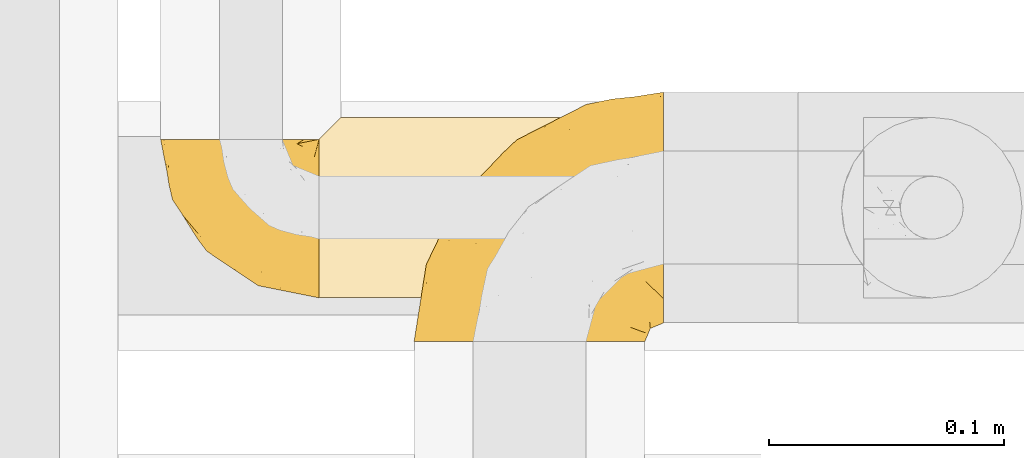
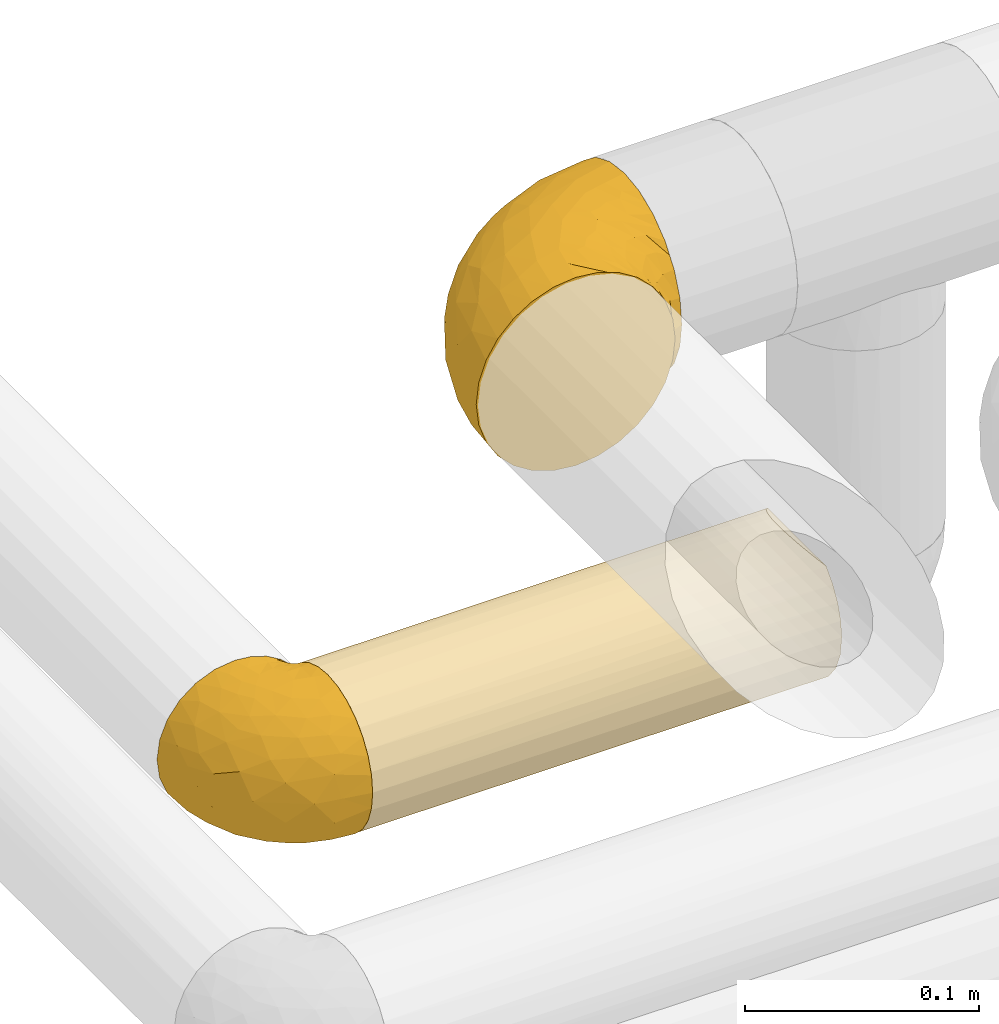
# One storey, part 361 of 827: 3 coverings.
"""IFC2X3 building model written with IfcOpenShell, lengths in millimetres."""

from ifc_helpers import new_model, entity, si_unit, converted_unit, derived_unit, direction, frame, origin, place, context, subcontext, project, spatial, faceted_brep, element, save


model = new_model("IFC2X3")

# Units and contexts
model_context = context("Model", 3, precision=0.01, world=origin(), true_north=direction((6.12303176911189e-17, 1.0)))
body_context = subcontext(model_context, "Body", "Model", "MODEL_VIEW")
ifc_project = project(units=[si_unit("LENGTHUNIT", "METRE", prefix="MILLI"), si_unit("AREAUNIT", "SQUARE_METRE"), si_unit("VOLUMEUNIT", "CUBIC_METRE"), converted_unit("PLANEANGLEUNIT", "DEGREE", entity("IfcRatioMeasure", 0.0174532925199433), si_unit("PLANEANGLEUNIT", "RADIAN"), dimensions=[0, 0, 0, 0, 0, 0, 0]), si_unit("MASSUNIT", "GRAM", prefix="KILO"), derived_unit("MASSDENSITYUNIT", [(si_unit("MASSUNIT", "GRAM", prefix="KILO"), 1), (si_unit("LENGTHUNIT", "METRE"), -3)]), derived_unit("MOMENTOFINERTIAUNIT", [(si_unit("LENGTHUNIT", "METRE"), 4)]), si_unit("TIMEUNIT", "SECOND"), si_unit("FREQUENCYUNIT", "HERTZ"), si_unit("THERMODYNAMICTEMPERATUREUNIT", "DEGREE_CELSIUS"), derived_unit("THERMALTRANSMITTANCEUNIT", [(si_unit("MASSUNIT", "GRAM", prefix="KILO"), 1), (si_unit("THERMODYNAMICTEMPERATUREUNIT", "KELVIN"), -1), (si_unit("TIMEUNIT", "SECOND"), -3)]), derived_unit("VOLUMETRICFLOWRATEUNIT", [(si_unit("LENGTHUNIT", "METRE"), 3), (si_unit("TIMEUNIT", "SECOND"), -1)]), derived_unit("MASSFLOWRATEUNIT", [(si_unit("MASSUNIT", "GRAM", prefix="KILO"), 1), (si_unit("TIMEUNIT", "SECOND"), -1)]), derived_unit("ROTATIONALFREQUENCYUNIT", [(si_unit("TIMEUNIT", "SECOND"), -1)]), si_unit("ELECTRICCURRENTUNIT", "AMPERE"), si_unit("ELECTRICVOLTAGEUNIT", "VOLT"), si_unit("POWERUNIT", "WATT"), si_unit("FORCEUNIT", "NEWTON", prefix="KILO"), si_unit("ILLUMINANCEUNIT", "LUX"), si_unit("LUMINOUSFLUXUNIT", "LUMEN"), si_unit("LUMINOUSINTENSITYUNIT", "CANDELA"), derived_unit("USERDEFINED", [(si_unit("MASSUNIT", "GRAM", prefix="KILO"), -1), (si_unit("LENGTHUNIT", "METRE"), -2), (si_unit("TIMEUNIT", "SECOND"), 3), (si_unit("LUMINOUSFLUXUNIT", "LUMEN"), 1)]), derived_unit("LINEARVELOCITYUNIT", [(si_unit("LENGTHUNIT", "METRE"), 1), (si_unit("TIMEUNIT", "SECOND"), -1)]), si_unit("PRESSUREUNIT", "PASCAL"), derived_unit("USERDEFINED", [(si_unit("LENGTHUNIT", "METRE"), -2), (si_unit("MASSUNIT", "GRAM", prefix="KILO"), 1), (si_unit("TIMEUNIT", "SECOND"), -2)]), derived_unit("LINEARFORCEUNIT", [(si_unit("MASSUNIT", "GRAM", prefix="KILO"), 1), (si_unit("LENGTHUNIT", "METRE"), 1), (si_unit("TIMEUNIT", "SECOND"), -2), (si_unit("LENGTHUNIT", "METRE"), -1)]), derived_unit("PLANARFORCEUNIT", [(si_unit("MASSUNIT", "GRAM", prefix="KILO"), 1), (si_unit("LENGTHUNIT", "METRE"), 1), (si_unit("TIMEUNIT", "SECOND"), -2), (si_unit("LENGTHUNIT", "METRE"), -2)])], contexts=[model_context])

# Site, building, storey
site_placement = place(None, origin())
site = spatial("IfcSite", under=ifc_project, at=site_placement, CompositionType="ELEMENT")
building_placement = place(site_placement, origin())
building = spatial("IfcBuilding", under=site, at=building_placement, CompositionType="ELEMENT")
storey_placement = place(building_placement, frame((0.0, 0.0, 28200.0)))
storey = spatial("IfcBuildingStorey", under=building, at=storey_placement, Name="08", CompositionType="ELEMENT", Elevation=28200.0)

# Coverings
covering_1_placement = place(storey_placement, frame((36417.97, 19056.89, 3349.15)))
element("IfcCovering", 1, at=covering_1_placement, inside=storey, Name=":ADSK_", ObjectType=":ADSK_", PredefinedType="INSULATION", context=body_context, shape_type="Brep", body=[
    faceted_brep([(50.75, 1.6, 99.9), (39.8, 1.6, 98.66), (29.41, 1.6, 95.02), (20.09, 1.6, 89.17), (12.31, 1.6, 81.38), (6.46, 1.6, 72.06), (2.83, 1.6, 61.68), (1.6, 1.6, 50.75), (2.83, 1.6, 39.8), (6.47, 1.6, 29.41), (12.32, 1.6, 20.09), (20.11, 1.6, 12.31), (29.43, 1.6, 6.46), (39.81, 1.6, 2.83), (50.75, 1.6, 1.6), (56.45, 1.6, 2.24), (61.69, 1.6, 2.83), (66.88, 1.6, 4.65), (72.08, 1.6, 6.47), (81.4, 1.6, 12.32), (89.18, 1.6, 20.11), (95.03, 1.6, 29.43), (98.66, 1.6, 39.81), (99.9, 1.6, 50.75), (98.66, 1.6, 61.69), (95.02, 1.6, 72.08), (89.17, 1.6, 81.4), (81.38, 1.6, 89.18), (72.06, 1.6, 95.03), (66.87, 1.6, 96.85), (61.68, 1.6, 98.66), (56.45, 1.6, 99.25), (53.6, 1.6, 99.57), (107.75, 11.12, 38.02), (107.75, 16.03, 26.17), (107.75, 19.94, 21.08), (107.75, 23.84, 15.99), (107.75, 28.93, 12.09), (107.75, 34.02, 8.18), (107.75, 39.95, 5.73), (107.75, 45.87, 3.27), (107.75, 52.86, 2.35), (107.75, 55.73, 1.97), (107.75, 58.6, 1.6), (107.75, 71.32, 3.27), (107.75, 83.17, 8.18), (107.75, 93.35, 15.99), (107.75, 101.16, 26.17), (107.75, 106.07, 38.02), (107.75, 107.75, 50.75), (107.75, 106.07, 63.47), (107.75, 101.16, 75.32), (107.75, 93.35, 85.5), (107.75, 83.17, 93.31), (107.75, 71.32, 98.22), (107.75, 58.6, 99.9), (107.75, 52.86, 99.14), (107.75, 45.87, 98.22), (107.75, 39.95, 95.77), (107.75, 34.02, 93.31), (107.75, 28.93, 89.4), (107.75, 23.84, 85.5), (107.75, 19.94, 80.41), (107.75, 16.03, 75.32), (107.75, 11.12, 63.47), (107.75, 9.45, 50.75), (39.38, 81.82, 59.31), (49.75, 84.02, 73.08), (57.38, 93.05, 63.72), (74.94, 102.55, 50.75), (85.97, 104.83, 58.64), (95.66, 105.83, 50.75), (67.82, 91.87, 76.74), (83.09, 101.74, 67.68), (89.16, 97.07, 78.92), (37.01, 38.45, 94.31), (43.46, 22.17, 98.76), (51.79, 42.04, 98.4), (85.58, 77.69, 94.57), (62.84, 75.76, 89.91), (62.77, 62.11, 96.32), (88.17, 66.08, 98.79), (85.93, 54.26, 99.9), (91.42, 55.35, 99.9), (96.91, 56.44, 99.9), (99.62, 56.98, 99.9), (102.33, 57.52, 99.9), (82.57, 87.84, 87.31), (32.75, 19.41, 95.61), (13.79, 48.89, 60.43), (6.77, 26.34, 65.24), (16.46, 44.55, 72.87), (55.08, 23.41, 99.9), (58.17, 28.03, 99.9), (61.26, 32.65, 99.9), (64.35, 37.28, 99.9), (67.44, 41.9, 99.9), (24.18, 20.6, 90.65), (23.37, 63.36, 63.14), (49.76, 62.21, 91.89), (9.84, 19.94, 75.25), (3.51, 13.68, 50.75), (55.75, 80.85, 82.18), (42.34, 66.53, 85.08), (37.78, 71.06, 76.93), (21.87, 63.99, 50.75), (33.61, 75.73, 50.75), (17.1, 26.77, 83.02), (51.28, 4.31, 99.9), (51.82, 7.01, 99.9), (52.9, 12.43, 99.9), (53.99, 17.92, 99.9), (28.01, 43.43, 87.13), (28.99, 56.23, 80.85), (69.9, 54.97, 99.17), (6.79, 34.4, 50.75), (72.06, 44.99, 99.9), (76.69, 48.08, 99.9), (81.31, 51.17, 99.9), (45.35, 87.47, 50.75), (34.79, 74.55, 67.61), (25.72, 60.86, 72.25), (14.33, 49.19, 50.75), (60.15, 95.01, 50.75), (62.38, 10.27, 98.69), (100.57, 48.79, 99.01), (91.06, 45.16, 98.79), (97.66, 44.99, 98.29), (97.55, 6.17, 68.51), (93.65, 7.65, 76.82), (66.85, 21.59, 98.54), (61.93, 19.96, 99.3), (101.4, 21.0, 83.57), (100.07, 27.2, 89.47), (101.36, 14.83, 75.76), (95.94, 19.7, 84.86), (96.3, 10.93, 75.89), (101.98, 9.63, 64.77), (85.88, 19.97, 90.83), (78.88, 21.13, 94.62), (82.8, 14.14, 90.37), (102.58, 30.2, 91.18), (82.88, 8.12, 88.65), (88.57, 9.93, 84.11), (88.67, 24.62, 91.75), (69.08, 11.87, 96.86), (102.19, 7.15, 50.75), (100.06, 5.32, 58.97), (70.56, 26.68, 98.37), (91.07, 13.92, 83.91), (77.56, 30.67, 97.52), (96.59, 36.65, 95.55), (86.38, 42.89, 98.76), (91.79, 34.04, 95.26), (81.71, 36.6, 98.04), (94.11, 26.41, 90.65), (76.09, 10.07, 93.51), (76.91, 15.83, 94.16), (81.44, 41.99, 99.1), (101.37, 14.83, 25.73), (94.12, 26.4, 10.84), (101.41, 21.01, 17.92), (95.96, 19.71, 16.64), (96.22, 5.72, 30.44), (66.85, 21.6, 2.95), (61.94, 19.96, 2.19), (58.17, 28.03, 1.6), (69.1, 11.87, 4.63), (88.58, 9.93, 17.39), (96.91, 56.44, 1.6), (102.33, 57.52, 1.6), (105.04, 58.06, 1.6), (82.9, 8.13, 12.86), (82.82, 14.15, 11.13), (97.66, 44.99, 3.2), (96.59, 36.65, 5.94), (100.07, 27.21, 12.02), (91.79, 34.04, 6.23), (102.58, 30.2, 10.31), (76.13, 10.06, 8.0), (76.93, 15.83, 7.34), (100.57, 48.79, 2.48), (86.38, 42.89, 2.73), (90.86, 45.38, 2.64), (52.9, 12.43, 1.6), (62.39, 10.28, 2.8), (101.98, 9.64, 36.71), (91.42, 55.35, 1.6), (85.93, 54.26, 1.6), (99.49, 6.05, 38.59), (51.82, 7.01, 1.6), (52.36, 9.72, 1.6), (61.26, 32.65, 1.6), (70.56, 26.68, 3.12), (91.09, 13.92, 17.59), (64.35, 37.28, 1.6), (77.6, 30.66, 3.98), (78.89, 21.14, 6.87), (81.71, 36.59, 3.45), (88.69, 24.6, 9.76), (53.99, 17.92, 1.6), (55.08, 23.41, 1.6), (96.31, 10.93, 25.62), (85.9, 19.97, 10.67), (81.45, 41.99, 2.39), (76.69, 48.08, 1.6), (81.31, 51.17, 1.6), (72.06, 44.99, 1.6), (67.44, 41.9, 1.6), (69.6, 55.26, 2.4), (85.97, 104.83, 42.85), (82.57, 87.84, 14.18), (63.16, 75.91, 11.56), (55.81, 80.84, 19.27), (67.81, 91.87, 24.75), (49.73, 83.98, 28.37), (32.55, 19.16, 5.95), (43.23, 22.37, 2.79), (88.17, 66.08, 2.71), (57.38, 93.05, 37.78), (83.08, 101.74, 33.81), (89.16, 97.07, 22.57), (85.58, 77.69, 6.92), (16.46, 44.55, 28.61), (6.77, 26.34, 36.24), (13.8, 48.9, 41.05), (37.71, 70.99, 24.55), (34.8, 74.55, 33.88), (36.83, 37.8, 7.11), (39.38, 81.82, 42.18), (17.12, 26.77, 18.46), (24.19, 20.6, 10.84), (28.89, 56.15, 20.69), (25.69, 60.85, 29.27), (51.77, 42.06, 3.1), (45.66, 57.03, 9.18), (23.39, 63.4, 38.38), (9.85, 19.94, 26.23), (28.11, 43.59, 14.34), (62.27, 62.61, 5.46), (42.35, 66.52, 16.39)], [[[0, 1, 2, 3, 4, 5, 6, 7, 8, 9, 10, 11, 12, 13, 14, 15, 16, 17, 18, 19, 20, 21, 22, 23, 24, 25, 26, 27, 28, 29, 30, 31, 32]], [[33, 34, 35, 36, 37, 38, 39, 40, 41, 42, 43, 44, 45, 46, 47, 48, 49, 50, 51, 52, 53, 54, 55, 56, 57, 58, 59, 60, 61, 62, 63, 64, 65]], [[66, 67, 68]], [[69, 70, 71]], [[68, 72, 73]], [[73, 72, 74]], [[75, 76, 77]], [[78, 79, 80]], [[51, 50, 73]], [[81, 82, 83, 84, 85, 86, 55]], [[52, 87, 53]], [[74, 52, 51]], [[2, 1, 88]], [[89, 90, 91]], [[77, 92, 93, 94, 95, 96]], [[55, 54, 81]], [[78, 53, 87]], [[5, 90, 6]], [[88, 76, 75]], [[97, 3, 2]], [[89, 91, 98]], [[99, 80, 79]], [[90, 5, 100]], [[74, 87, 52]], [[100, 5, 4]], [[90, 101, 6]], [[79, 102, 103]], [[102, 67, 104]], [[105, 98, 106]], [[107, 4, 3]], [[76, 0, 108, 109, 110, 111, 92]], [[107, 112, 113]], [[114, 77, 96]], [[89, 115, 90]], [[114, 96, 116, 117, 118, 82]], [[75, 97, 88]], [[119, 66, 68]], [[50, 71, 70]], [[100, 91, 90]], [[99, 77, 80]], [[102, 104, 103]], [[97, 107, 3]], [[80, 81, 78]], [[107, 97, 112]], [[68, 73, 70]], [[66, 98, 120]], [[78, 81, 54]], [[114, 81, 80]], [[53, 78, 54]], [[78, 87, 79]], [[102, 87, 72]], [[79, 103, 99]], [[4, 107, 100]], [[91, 100, 107]], [[88, 97, 2]], [[112, 97, 75]], [[99, 112, 75]], [[103, 104, 113]], [[91, 121, 98]], [[89, 105, 122, 115]], [[101, 90, 115]], [[101, 7, 6]], [[88, 1, 76]], [[0, 76, 1]], [[92, 77, 76]], [[73, 74, 51]], [[87, 74, 72]], [[81, 114, 82]], [[77, 114, 80]], [[87, 102, 79]], [[67, 102, 72]], [[68, 67, 72]], [[67, 120, 104]], [[120, 121, 104]], [[104, 121, 113]], [[121, 120, 98]], [[91, 107, 113]], [[91, 113, 121]], [[103, 113, 112]], [[106, 98, 66]], [[105, 89, 98]], [[106, 66, 119]], [[67, 66, 120]], [[68, 69, 123, 119]], [[50, 49, 71]], [[50, 70, 73]], [[112, 99, 103]], [[77, 99, 75]], [[69, 68, 70]], [[29, 124, 110]], [[84, 83, 125]], [[126, 82, 118]], [[59, 58, 127]], [[25, 128, 129]], [[130, 93, 131]], [[132, 62, 133]], [[134, 135, 136]], [[137, 65, 64]], [[64, 134, 137]], [[138, 139, 140]], [[111, 110, 124, 92]], [[134, 136, 137]], [[134, 64, 63]], [[141, 61, 60]], [[125, 58, 57]], [[142, 143, 140]], [[142, 26, 143]], [[127, 83, 82]], [[28, 124, 29]], [[108, 0, 32, 31, 30, 110, 109]], [[30, 29, 110]], [[135, 144, 138]], [[28, 145, 124]], [[57, 56, 55, 86, 85, 84]], [[146, 147, 23]], [[24, 23, 147]], [[25, 143, 26]], [[95, 94, 148]], [[24, 128, 25]], [[149, 138, 143]], [[124, 145, 131]], [[127, 58, 125]], [[150, 148, 139]], [[127, 126, 151]], [[151, 59, 127]], [[152, 151, 126]], [[153, 154, 155]], [[153, 133, 141]], [[145, 28, 27]], [[142, 156, 27]], [[157, 148, 130]], [[61, 133, 62]], [[134, 132, 135]], [[147, 128, 24]], [[65, 137, 146]], [[146, 137, 147]], [[128, 137, 136]], [[137, 128, 147]], [[128, 136, 129]], [[149, 129, 136]], [[25, 129, 143]], [[158, 152, 117]], [[152, 118, 117]], [[153, 151, 152]], [[158, 116, 154]], [[144, 150, 138]], [[153, 152, 158]], [[133, 153, 155]], [[133, 155, 132]], [[60, 151, 141]], [[135, 132, 155]], [[134, 63, 132]], [[144, 135, 155]], [[135, 138, 149]], [[155, 154, 144]], [[150, 154, 96]], [[154, 150, 144]], [[148, 94, 130]], [[82, 126, 127]], [[118, 152, 126]], [[150, 96, 95]], [[139, 148, 157]], [[150, 95, 148]], [[93, 92, 131]], [[130, 145, 156]], [[130, 94, 93]], [[84, 125, 57]], [[127, 125, 83]], [[140, 139, 157]], [[150, 139, 138]], [[140, 157, 142]], [[138, 140, 143]], [[156, 142, 157]], [[27, 26, 142]], [[130, 156, 157]], [[145, 27, 156]], [[132, 63, 62]], [[124, 131, 92]], [[130, 131, 145]], [[129, 149, 143]], [[135, 149, 136]], [[141, 133, 61]], [[60, 59, 151]], [[141, 151, 153]], [[116, 96, 154]], [[153, 158, 154]], [[158, 117, 116]], [[34, 33, 159]], [[160, 161, 162]], [[22, 21, 163]], [[164, 165, 166]], [[19, 18, 167]], [[168, 21, 20]], [[42, 41, 40, 169, 170, 171, 43]], [[172, 173, 168]], [[174, 38, 175]], [[176, 177, 178]], [[179, 164, 180]], [[40, 181, 169]], [[182, 183, 175]], [[17, 184, 185]], [[65, 146, 186]], [[187, 174, 188]], [[23, 22, 189]], [[174, 39, 38]], [[15, 14, 190, 191, 184, 16]], [[181, 40, 39]], [[192, 193, 164]], [[194, 163, 168]], [[33, 186, 159]], [[180, 173, 172]], [[195, 196, 193]], [[18, 185, 167]], [[173, 180, 197]], [[198, 199, 196]], [[200, 201, 185, 184]], [[184, 17, 16]], [[18, 17, 185]], [[202, 159, 186]], [[194, 168, 203]], [[189, 163, 202]], [[204, 205, 182]], [[187, 181, 174]], [[160, 177, 176]], [[206, 183, 182]], [[206, 182, 205]], [[201, 165, 185]], [[165, 164, 167]], [[172, 179, 180]], [[202, 194, 162]], [[176, 161, 160]], [[65, 186, 33]], [[163, 189, 22]], [[175, 177, 182]], [[174, 183, 188]], [[177, 198, 204]], [[199, 160, 162]], [[198, 207, 204]], [[175, 38, 37]], [[198, 177, 160]], [[178, 177, 175]], [[176, 35, 161]], [[34, 159, 161]], [[162, 161, 159]], [[202, 162, 159]], [[199, 162, 203]], [[196, 199, 203]], [[198, 160, 199]], [[193, 197, 180]], [[208, 198, 196]], [[188, 183, 206]], [[175, 183, 174]], [[193, 192, 195]], [[195, 208, 196]], [[197, 196, 203]], [[180, 164, 193]], [[168, 163, 21]], [[166, 165, 201]], [[166, 192, 164]], [[189, 202, 186]], [[186, 146, 189]], [[23, 189, 146]], [[174, 181, 39]], [[169, 181, 187]], [[196, 197, 193]], [[173, 203, 168]], [[203, 173, 197]], [[172, 168, 20]], [[20, 19, 172]], [[179, 172, 19]], [[19, 167, 179]], [[164, 179, 167]], [[35, 176, 36]], [[35, 34, 161]], [[185, 165, 167]], [[162, 194, 203]], [[163, 194, 202]], [[176, 178, 36]], [[37, 36, 178]], [[175, 37, 178]], [[177, 204, 182]], [[207, 198, 208]], [[207, 205, 204]], [[209, 188, 206, 205, 207, 208]], [[48, 210, 71]], [[211, 212, 213]], [[214, 213, 215]], [[216, 217, 13]], [[218, 43, 171, 170, 169, 187, 188]], [[219, 220, 214]], [[47, 46, 221]], [[210, 48, 220]], [[211, 222, 212]], [[222, 45, 44]], [[221, 220, 47]], [[47, 220, 48]], [[221, 211, 214]], [[223, 224, 225]], [[211, 46, 45]], [[226, 227, 215]], [[43, 218, 44]], [[217, 216, 228]], [[219, 215, 229]], [[14, 13, 217]], [[224, 9, 8]], [[10, 230, 11]], [[11, 231, 12]], [[232, 223, 233]], [[234, 208, 195, 192, 166, 201]], [[235, 234, 228]], [[222, 44, 218]], [[106, 229, 236]], [[224, 237, 9]], [[231, 238, 228]], [[9, 237, 10]], [[115, 224, 101]], [[239, 234, 235]], [[231, 11, 230]], [[223, 230, 237]], [[224, 8, 101]], [[223, 236, 233]], [[225, 115, 122, 105]], [[216, 12, 231]], [[209, 234, 239]], [[210, 219, 69]], [[219, 214, 215]], [[229, 119, 219]], [[209, 218, 188]], [[239, 212, 222]], [[239, 222, 218]], [[45, 222, 211]], [[235, 212, 239]], [[213, 212, 240]], [[223, 237, 224]], [[230, 10, 237]], [[238, 231, 230]], [[216, 231, 228]], [[232, 230, 223]], [[235, 238, 240]], [[115, 225, 224]], [[233, 236, 227]], [[8, 7, 101]], [[234, 209, 208]], [[218, 209, 239]], [[217, 228, 234]], [[13, 12, 216]], [[234, 201, 217]], [[217, 201, 200, 184, 191, 190, 14]], [[211, 221, 46]], [[220, 221, 214]], [[71, 210, 69]], [[71, 49, 48]], [[219, 210, 220]], [[226, 215, 213]], [[211, 213, 214]], [[226, 213, 240]], [[215, 227, 229]], [[232, 240, 238]], [[233, 227, 226]], [[232, 233, 226]], [[236, 223, 225]], [[240, 232, 226]], [[232, 238, 230]], [[225, 105, 236]], [[236, 105, 106]], [[236, 229, 227]], [[123, 69, 219, 119]], [[106, 119, 229]], [[238, 235, 228]], [[212, 235, 240]]]),
])
covering_2_placement = place(storey_placement, frame((36377.53, 19075.49, 3160.0)))
element("IfcCovering", 2, at=covering_2_placement, inside=storey, Name=":ADSK_", ObjectType=":ADSK_", PredefinedType="INSULATION", context=body_context, shape_type="Brep", body=[
    faceted_brep([(1.6, 20.8, 6.74), (1.6, 12.84, 12.84), (1.6, 6.74, 20.8), (1.6, 2.9, 30.06), (1.6, 1.6, 40.0), (1.6, 2.9, 49.93), (1.6, 6.74, 59.2), (1.6, 12.84, 67.15), (1.6, 20.8, 73.25), (1.6, 30.06, 77.09), (1.6, 40.0, 78.4), (1.6, 48.2, 77.51), (1.6, 56.01, 74.9), (1.6, 63.08, 70.68), (1.6, 69.1, 65.05), (1.6, 69.1, 14.94), (1.6, 63.08, 9.31), (1.6, 56.01, 5.09), (1.6, 48.2, 2.48), (1.6, 40.0, 1.6), (1.6, 30.06, 2.9), (233.4, 2.9, 30.06), (233.4, 6.74, 20.8), (233.4, 12.84, 12.84), (233.4, 20.8, 6.74), (233.4, 30.06, 2.9), (233.4, 40.0, 1.6), (233.4, 49.93, 2.9), (233.4, 59.2, 6.74), (233.4, 67.15, 12.84), (233.4, 73.25, 20.8), (233.4, 77.09, 30.06), (233.4, 78.4, 40.0), (233.4, 77.51, 48.2), (233.4, 74.9, 56.01), (233.4, 70.68, 63.08), (233.4, 65.05, 69.1), (233.4, 14.94, 69.1), (233.4, 9.31, 63.08), (233.4, 5.09, 56.01), (233.4, 2.48, 48.2), (233.4, 1.6, 40.0), (10.29, 77.79, 33.21), (10.9, 78.4, 40.0), (8.5, 76.0, 26.63), (5.57, 73.07, 20.48), (229.42, 20.48, 73.07), (226.5, 26.63, 76.0), (224.7, 33.21, 77.79), (224.1, 40.0, 78.4), (224.7, 46.78, 77.79), (226.5, 53.36, 76.0), (229.42, 59.51, 73.07), (5.57, 73.07, 59.51), (8.5, 76.0, 53.36), (10.29, 77.79, 46.78)], [[[0, 1, 2, 3, 4, 5, 6, 7, 8, 9, 10, 11, 12, 13, 14, 15, 16, 17, 18, 19, 20]], [[21, 22, 23, 24, 25, 26, 27, 28, 29, 30, 31, 32, 33, 34, 35, 36, 37, 38, 39, 40, 41]], [[42, 43, 32]], [[42, 32, 31]], [[44, 31, 30]], [[44, 42, 31]], [[15, 45, 30]], [[44, 30, 45]], [[30, 29, 15]], [[16, 29, 28]], [[17, 28, 27]], [[18, 27, 26]], [[16, 28, 17]], [[17, 27, 18]], [[26, 19, 18]], [[29, 16, 15]], [[20, 19, 26, 25]], [[0, 20, 25, 24]], [[24, 23, 1, 0]], [[3, 2, 22, 21]], [[4, 3, 21, 41]], [[23, 22, 2, 1]], [[4, 41, 40]], [[5, 40, 39]], [[6, 39, 38]], [[4, 40, 5]], [[5, 39, 6]], [[38, 7, 6]], [[38, 37, 7]], [[37, 46, 8]], [[47, 48, 9]], [[46, 47, 8]], [[8, 47, 9]], [[10, 9, 48]], [[49, 10, 48]], [[37, 8, 7]], [[50, 51, 11]], [[52, 36, 13]], [[51, 52, 12]], [[49, 50, 10]], [[11, 10, 50]], [[51, 12, 11]], [[52, 13, 12]], [[36, 14, 13]], [[53, 35, 34]], [[54, 34, 33]], [[55, 33, 32]], [[53, 14, 35]], [[55, 54, 33]], [[43, 55, 32]], [[53, 34, 54]], [[35, 14, 36]], [[14, 53, 54, 55, 43, 42, 44, 45, 15]], [[50, 49, 48, 47, 46, 37, 36, 52, 51]]]),
])
covering_3_placement = place(storey_placement, frame((36309.98, 19075.44, 3159.95)))
element("IfcCovering", 3, at=covering_3_placement, inside=storey, Name=":ADSK_", ObjectType=":ADSK_", PredefinedType="INSULATION", context=body_context, shape_type="Brep", body=[
    faceted_brep([(69.15, 23.36, 74.68), (69.15, 16.07, 70.1), (69.15, 9.98, 64.01), (69.15, 5.4, 56.72), (69.15, 2.56, 48.6), (69.15, 1.6, 40.05), (69.15, 2.56, 31.49), (69.15, 5.41, 23.36), (69.15, 9.99, 16.07), (69.15, 16.08, 9.98), (69.15, 23.37, 5.4), (69.15, 31.49, 2.56), (69.15, 40.05, 1.6), (69.15, 48.15, 2.46), (69.15, 55.88, 5.01), (69.15, 62.9, 9.13), (69.15, 68.89, 14.62), (69.15, 68.89, 16.82), (69.15, 68.89, 18.56), (69.15, 68.89, 20.52), (69.15, 68.89, 22.49), (69.15, 68.89, 24.46), (69.15, 68.89, 26.42), (69.15, 68.89, 28.39), (69.15, 68.89, 30.36), (69.15, 68.89, 32.55), (69.15, 68.89, 34.75), (69.15, 68.89, 36.94), (69.15, 68.89, 39.13), (69.15, 68.89, 41.33), (69.15, 68.89, 43.52), (69.15, 68.89, 45.72), (69.15, 68.89, 47.91), (69.15, 68.89, 50.11), (69.15, 68.89, 52.3), (69.15, 68.89, 54.49), (69.15, 68.89, 56.69), (69.15, 68.89, 58.88), (69.15, 68.89, 61.08), (69.15, 68.89, 63.27), (69.15, 68.89, 65.47), (69.15, 62.89, 70.97), (69.15, 55.86, 75.09), (69.15, 48.13, 77.64), (69.15, 40.05, 78.5), (69.15, 31.49, 77.53), (68.89, 69.15, 14.62), (62.89, 69.15, 9.12), (55.87, 69.15, 5.0), (48.14, 69.15, 2.46), (40.05, 69.15, 1.6), (30.09, 69.15, 2.91), (20.82, 69.15, 6.75), (12.86, 69.15, 12.86), (6.75, 69.15, 20.82), (2.91, 69.15, 30.09), (1.6, 69.15, 40.05), (2.91, 69.15, 50.0), (6.75, 69.15, 59.27), (12.86, 69.15, 67.23), (20.82, 69.15, 73.34), (30.09, 69.15, 77.19), (40.05, 69.15, 78.5), (48.14, 69.15, 77.63), (55.87, 69.15, 75.09), (62.89, 69.15, 70.97), (68.89, 69.15, 65.47), (68.89, 69.15, 63.27), (68.89, 69.15, 62.29), (68.89, 69.15, 60.7), (68.89, 69.15, 59.11), (68.89, 69.15, 57.52), (68.89, 69.15, 55.93), (68.89, 69.15, 54.34), (68.89, 69.15, 52.76), (68.89, 69.15, 51.17), (68.89, 69.15, 49.58), (68.89, 69.15, 47.99), (68.89, 69.15, 46.4), (68.89, 69.15, 44.81), (68.89, 69.15, 43.22), (68.89, 69.15, 41.63), (68.89, 69.15, 40.05), (68.89, 69.15, 38.46), (68.89, 69.15, 36.87), (68.89, 69.15, 35.28), (68.89, 69.15, 33.69), (68.89, 69.15, 32.1), (68.89, 69.15, 30.51), (68.89, 69.15, 28.92), (68.89, 69.15, 27.33), (68.89, 69.15, 25.37), (68.89, 69.15, 23.4), (68.89, 69.15, 21.21), (68.89, 69.15, 19.01), (68.89, 69.15, 16.82), (68.97, 68.96, 42.32), (68.96, 68.97, 44.02), (68.97, 68.97, 47.13), (68.97, 68.97, 48.74), (68.98, 68.95, 23.57), (68.97, 68.96, 25.13), (68.96, 68.98, 61.34), (68.96, 68.97, 22.02), (68.96, 68.97, 29.72), (68.96, 68.98, 56.73), (68.96, 68.97, 55.14), (68.96, 68.97, 37.66), (69.0, 68.94, 64.12), (68.96, 68.98, 28.13), (68.96, 68.98, 26.62), (68.97, 68.96, 31.46), (68.96, 68.97, 16.16), (68.96, 68.98, 39.16), (68.96, 68.98, 50.37), (68.97, 68.97, 17.69), (68.97, 68.96, 19.17), (68.97, 68.97, 62.78), (68.96, 68.97, 58.35), (68.96, 68.98, 45.53), (68.97, 68.96, 59.91), (68.97, 68.97, 65.47), (69.02, 68.94, 65.47), (69.08, 68.92, 65.47), (68.97, 68.97, 14.62), (68.94, 69.02, 14.62), (68.92, 69.08, 14.62), (68.96, 68.98, 20.59), (68.96, 68.97, 32.99), (68.95, 68.98, 34.48), (68.96, 68.97, 51.91), (68.92, 69.08, 65.47), (68.94, 69.02, 65.47), (68.98, 68.96, 53.48), (69.08, 68.92, 14.62), (69.02, 68.94, 14.62), (68.96, 68.97, 40.77), (68.97, 68.96, 35.97), (61.33, 67.02, 7.84), (53.1, 63.33, 3.53), (63.33, 64.61, 8.32), (49.27, 49.27, 1.6), (55.53, 51.4, 2.19), (54.6, 43.94, 1.6), (41.99, 61.87, 1.6), (57.07, 61.54, 4.57), (57.95, 57.95, 3.96), (51.56, 56.12, 2.28), (41.58, 63.4, 1.6), (61.7, 65.41, 7.69), (63.33, 53.1, 3.53), (65.0, 63.04, 8.32), (67.02, 61.33, 7.84), (61.87, 41.99, 1.6), (43.94, 54.6, 1.6), (61.21, 56.6, 4.34), (63.4, 41.58, 1.6), (33.11, 13.72, 29.63), (52.82, 5.82, 27.34), (43.3, 6.74, 40.05), (33.73, 58.82, 2.39), (36.52, 51.58, 2.43), (24.87, 42.09, 9.07), (14.17, 46.12, 16.64), (18.43, 55.56, 9.54), (28.67, 52.38, 4.52), (26.0, 61.54, 4.52), (49.25, 23.76, 7.49), (59.72, 20.5, 7.49), (55.1, 14.64, 12.85), (44.72, 41.77, 2.35), (34.15, 16.28, 22.66), (5.25, 49.4, 32.9), (6.75, 52.34, 25.33), (55.54, 4.3, 40.05), (10.47, 58.67, 16.64), (25.49, 25.26, 19.99), (35.53, 20.17, 16.37), (48.22, 34.7, 3.26), (58.71, 28.67, 3.75), (57.42, 8.62, 19.58), (34.84, 33.37, 7.5), (36.87, 41.35, 4.04), (45.01, 17.15, 13.94), (44.4, 12.68, 19.58), (23.96, 21.47, 28.21), (11.2, 41.11, 24.75), (10.56, 37.53, 31.42), (16.81, 30.64, 26.2), (17.38, 26.66, 33.36), (21.38, 21.38, 40.05), (32.34, 14.06, 40.05), (4.3, 55.54, 40.05), (20.65, 35.17, 16.14), (29.66, 29.04, 12.85), (39.6, 24.34, 10.47), (42.55, 29.33, 6.49), (6.74, 43.3, 40.05), (14.06, 32.34, 40.05), (26.84, 57.75, 75.57), (5.28, 49.41, 47.37), (18.52, 27.85, 52.91), (33.13, 13.7, 50.46), (55.1, 14.63, 67.23), (57.43, 8.61, 60.5), (20.72, 48.85, 70.55), (11.46, 54.13, 63.45), (17.69, 37.84, 62.61), (49.26, 23.75, 72.6), (59.73, 20.49, 72.6), (58.71, 28.66, 76.34), (29.72, 20.83, 59.34), (35.35, 55.15, 77.76), (43.94, 54.6, 78.5), (41.99, 61.87, 78.5), (63.4, 41.58, 78.5), (4.93, 57.58, 53.16), (17.46, 59.91, 70.55), (10.94, 36.94, 48.88), (8.92, 45.72, 54.76), (52.83, 5.82, 52.74), (29.34, 37.91, 71.93), (30.26, 50.18, 75.79), (44.4, 12.67, 60.5), (39.06, 49.29, 77.86), (43.06, 42.64, 77.64), (54.6, 43.94, 78.5), (49.27, 49.27, 78.5), (42.69, 19.45, 67.23), (48.2, 34.7, 76.82), (61.87, 41.99, 78.5), (33.44, 62.29, 77.8), (29.67, 29.01, 67.23), (38.5, 31.47, 73.2), (23.35, 37.18, 67.66), (34.97, 43.45, 75.99), (53.1, 63.33, 76.57), (59.68, 67.23, 73.21), (62.19, 66.07, 71.93), (64.11, 65.22, 71.07), (57.97, 61.99, 75.09), (57.95, 57.95, 76.13), (63.33, 53.09, 76.57), (51.77, 56.84, 77.69), (67.02, 61.33, 72.26), (64.98, 63.06, 71.77), (55.53, 51.41, 77.9), (61.22, 56.61, 75.75)], [[[0, 1, 2, 3, 4, 5, 6, 7, 8, 9, 10, 11, 12, 13, 14, 15, 16, 17, 18, 19, 20, 21, 22, 23, 24, 25, 26, 27, 28, 29, 30, 31, 32, 33, 34, 35, 36, 37, 38, 39, 40, 41, 42, 43, 44, 45]], [[46, 47, 48, 49, 50, 51, 52, 53, 54, 55, 56, 57, 58, 59, 60, 61, 62, 63, 64, 65, 66, 67, 68, 69, 70, 71, 72, 73, 74, 75, 76, 77, 78, 79, 80, 81, 82, 83, 84, 85, 86, 87, 88, 89, 90, 91, 92, 93, 94, 95]], [[96, 97, 30]], [[98, 77, 99]], [[100, 101, 21]], [[69, 68, 102]], [[20, 19, 103]], [[24, 23, 104]], [[20, 103, 100]], [[72, 105, 106]], [[84, 83, 107]], [[89, 88, 104]], [[108, 67, 66]], [[109, 110, 90]], [[111, 25, 24]], [[112, 17, 16]], [[82, 113, 83]], [[109, 23, 22]], [[114, 76, 75]], [[105, 36, 106]], [[104, 111, 24]], [[18, 115, 116]], [[97, 96, 80]], [[67, 108, 117]], [[105, 71, 118]], [[31, 97, 119]], [[102, 120, 69]], [[108, 121, 122, 123, 40]], [[112, 95, 115]], [[17, 115, 18]], [[94, 116, 115]], [[117, 68, 67]], [[38, 117, 39]], [[112, 124, 125, 126, 46]], [[17, 112, 115]], [[70, 120, 118]], [[39, 117, 108]], [[120, 38, 37]], [[120, 37, 118]], [[120, 70, 69]], [[116, 94, 127]], [[128, 86, 129]], [[117, 38, 102]], [[74, 130, 75]], [[99, 33, 32]], [[115, 95, 94]], [[39, 108, 40]], [[108, 66, 131, 132, 121]], [[105, 72, 71]], [[118, 37, 36]], [[71, 70, 118]], [[35, 106, 36]], [[36, 105, 118]], [[35, 133, 106]], [[74, 73, 133]], [[106, 133, 73]], [[99, 114, 33]], [[133, 35, 34]], [[73, 72, 106]], [[95, 112, 46]], [[112, 16, 134, 135, 124]], [[130, 114, 75]], [[99, 76, 114]], [[114, 130, 33]], [[34, 33, 130]], [[78, 77, 98]], [[98, 119, 78]], [[130, 133, 34]], [[133, 130, 74]], [[79, 97, 80]], [[98, 99, 32]], [[98, 32, 31]], [[77, 76, 99]], [[97, 79, 119]], [[136, 96, 29]], [[30, 97, 31]], [[136, 29, 28]], [[81, 80, 96]], [[29, 96, 30]], [[31, 119, 98]], [[119, 79, 78]], [[96, 136, 81]], [[82, 81, 136]], [[113, 107, 83]], [[84, 107, 137]], [[107, 27, 137]], [[113, 28, 107]], [[27, 107, 28]], [[85, 84, 137]], [[137, 27, 26]], [[113, 136, 28]], [[136, 113, 82]], [[109, 89, 104]], [[86, 85, 129]], [[89, 109, 90]], [[111, 87, 128]], [[26, 129, 137]], [[88, 111, 104]], [[25, 111, 128]], [[22, 110, 109]], [[23, 109, 104]], [[110, 91, 90]], [[100, 92, 101]], [[110, 22, 101]], [[91, 110, 101]], [[116, 19, 18]], [[111, 88, 87]], [[127, 103, 19]], [[25, 128, 26]], [[86, 128, 87]], [[128, 129, 26]], [[137, 129, 85]], [[120, 102, 38]], [[117, 102, 68]], [[91, 101, 92]], [[21, 101, 22]], [[93, 92, 103]], [[100, 21, 20]], [[100, 103, 92]], [[127, 93, 103]], [[93, 127, 94]], [[116, 127, 19]], [[126, 138, 47]], [[48, 138, 139]], [[140, 125, 124]], [[141, 142, 143]], [[144, 49, 139]], [[145, 140, 146]], [[48, 139, 49]], [[139, 145, 147]], [[49, 144, 148, 50]], [[126, 125, 149]], [[14, 13, 150]], [[151, 146, 140]], [[149, 140, 145]], [[152, 151, 135]], [[152, 14, 150]], [[16, 15, 134]], [[13, 153, 150]], [[124, 151, 140]], [[141, 147, 142]], [[14, 152, 15]], [[15, 152, 134]], [[47, 46, 126]], [[139, 154, 144]], [[138, 48, 47]], [[125, 140, 149]], [[135, 134, 152]], [[146, 155, 142]], [[145, 146, 147]], [[149, 139, 138]], [[147, 141, 154]], [[147, 146, 142]], [[139, 147, 154]], [[139, 149, 145]], [[149, 138, 126]], [[155, 146, 151]], [[150, 143, 142]], [[152, 155, 151]], [[150, 142, 155]], [[13, 12, 156, 153]], [[153, 143, 150]], [[152, 150, 155]], [[151, 124, 135]], [[157, 158, 159]], [[160, 154, 161]], [[162, 163, 164]], [[165, 166, 160]], [[167, 168, 169]], [[141, 170, 161]], [[156, 12, 11]], [[158, 157, 171]], [[172, 55, 173]], [[158, 6, 174]], [[175, 54, 53]], [[52, 166, 164]], [[52, 164, 53]], [[54, 175, 173]], [[166, 52, 51]], [[176, 177, 171]], [[178, 143, 179]], [[156, 11, 179]], [[8, 7, 180]], [[169, 9, 8]], [[179, 143, 153, 156]], [[179, 11, 10]], [[168, 179, 10]], [[181, 162, 182]], [[179, 167, 178]], [[183, 184, 177]], [[183, 169, 184]], [[176, 171, 185]], [[172, 186, 187]], [[158, 7, 6]], [[159, 158, 174]], [[184, 180, 158]], [[54, 173, 55]], [[180, 169, 8]], [[188, 189, 187]], [[9, 168, 10]], [[186, 188, 187]], [[190, 157, 159, 191]], [[55, 172, 192]], [[176, 193, 194]], [[161, 170, 182]], [[162, 164, 165]], [[175, 164, 163]], [[51, 50, 148]], [[167, 195, 196]], [[178, 182, 170]], [[6, 5, 174]], [[158, 180, 7]], [[169, 180, 184]], [[169, 168, 9]], [[179, 168, 167]], [[182, 162, 165]], [[162, 194, 193]], [[161, 165, 160]], [[195, 181, 196]], [[192, 172, 197]], [[192, 56, 55]], [[189, 190, 198]], [[198, 197, 187]], [[172, 187, 197]], [[185, 189, 188]], [[198, 187, 189]], [[186, 172, 173]], [[173, 163, 186]], [[193, 186, 163]], [[176, 185, 188]], [[185, 157, 190]], [[188, 186, 193]], [[177, 176, 194]], [[188, 193, 176]], [[162, 193, 163]], [[195, 177, 194]], [[171, 177, 184]], [[181, 195, 194]], [[183, 167, 169]], [[162, 181, 194]], [[196, 182, 178]], [[158, 171, 184]], [[171, 157, 185]], [[177, 195, 183]], [[167, 183, 195]], [[182, 196, 181]], [[178, 170, 143]], [[178, 167, 196]], [[164, 175, 53]], [[173, 175, 163]], [[160, 51, 148]], [[164, 166, 165]], [[51, 160, 166]], [[160, 148, 144, 154]], [[141, 161, 154]], [[182, 165, 161]], [[190, 189, 185]], [[143, 170, 141]], [[60, 199, 61]], [[197, 200, 192]], [[201, 190, 202]], [[200, 57, 192]], [[203, 204, 2]], [[205, 206, 207]], [[208, 209, 210]], [[211, 207, 201]], [[212, 213, 214]], [[45, 215, 210]], [[216, 206, 58]], [[45, 44, 215]], [[59, 217, 60]], [[60, 217, 199]], [[0, 45, 210]], [[218, 201, 219]], [[202, 159, 220]], [[205, 221, 222]], [[223, 204, 203]], [[1, 203, 2]], [[57, 200, 216]], [[220, 3, 204]], [[220, 174, 4]], [[1, 0, 209]], [[212, 224, 213]], [[225, 226, 227]], [[228, 223, 203]], [[208, 210, 229]], [[210, 226, 229]], [[3, 220, 4]], [[58, 206, 59]], [[209, 203, 1]], [[202, 220, 223]], [[228, 203, 208]], [[202, 211, 201]], [[3, 2, 204]], [[202, 190, 191, 159]], [[210, 215, 230, 226]], [[199, 212, 231]], [[232, 233, 221]], [[233, 208, 229]], [[207, 206, 219]], [[217, 206, 205]], [[227, 224, 225]], [[233, 232, 228]], [[201, 207, 219]], [[234, 232, 221]], [[218, 219, 200]], [[202, 223, 211]], [[174, 220, 159]], [[174, 5, 4]], [[61, 231, 62]], [[220, 204, 223]], [[210, 209, 0]], [[203, 209, 208]], [[225, 233, 229]], [[224, 227, 213]], [[221, 233, 235]], [[57, 56, 192]], [[198, 218, 197]], [[200, 219, 216]], [[201, 198, 190]], [[197, 218, 200]], [[198, 201, 218]], [[206, 216, 219]], [[58, 57, 216]], [[231, 212, 214]], [[222, 212, 199]], [[228, 211, 223]], [[207, 211, 232]], [[62, 231, 214]], [[199, 231, 61]], [[233, 228, 208]], [[211, 228, 232]], [[222, 221, 235]], [[234, 205, 207]], [[206, 217, 59]], [[199, 217, 205]], [[205, 222, 199]], [[224, 222, 235]], [[222, 224, 212]], [[224, 235, 225]], [[233, 225, 235]], [[226, 225, 229]], [[205, 234, 221]], [[207, 232, 234]], [[63, 214, 236]], [[214, 213, 236]], [[214, 63, 62]], [[237, 236, 238]], [[238, 132, 131]], [[236, 237, 64]], [[239, 240, 241]], [[63, 236, 64]], [[131, 66, 65]], [[237, 131, 65]], [[242, 230, 43]], [[237, 65, 64]], [[239, 121, 132]], [[42, 242, 43]], [[241, 240, 243]], [[41, 123, 244]], [[43, 230, 215, 44]], [[244, 122, 245]], [[227, 246, 243]], [[241, 247, 245]], [[121, 239, 245]], [[41, 40, 123]], [[132, 238, 239]], [[244, 42, 41]], [[131, 237, 238]], [[240, 239, 238]], [[245, 239, 241]], [[247, 241, 246]], [[247, 244, 245]], [[238, 236, 240]], [[243, 236, 213]], [[236, 243, 240]], [[227, 226, 246]], [[243, 213, 227]], [[242, 246, 226]], [[243, 246, 241]], [[246, 242, 247]], [[244, 247, 242]], [[242, 226, 230]], [[42, 244, 242]], [[122, 244, 123]], [[122, 121, 245]]]),
])

save(model, "model.ifc")
